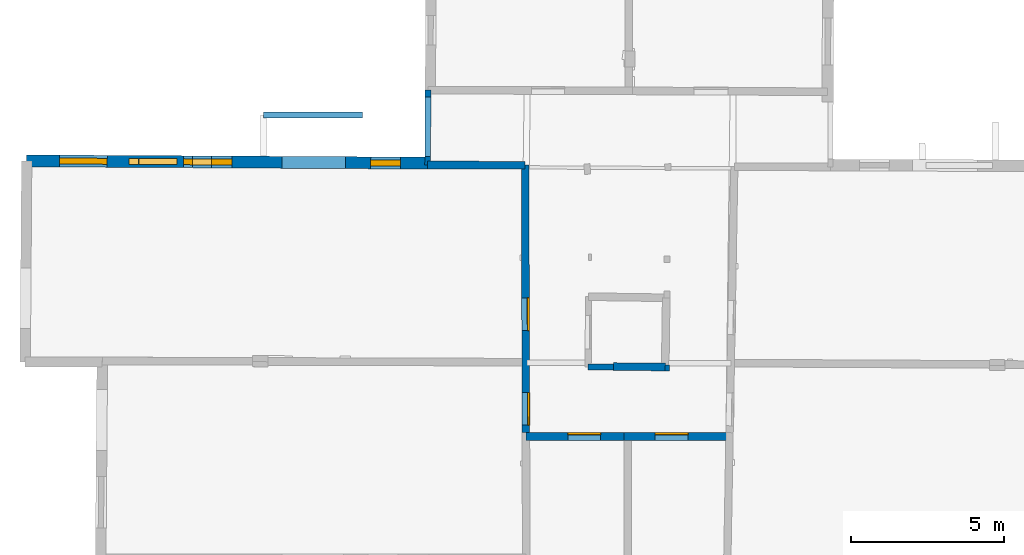
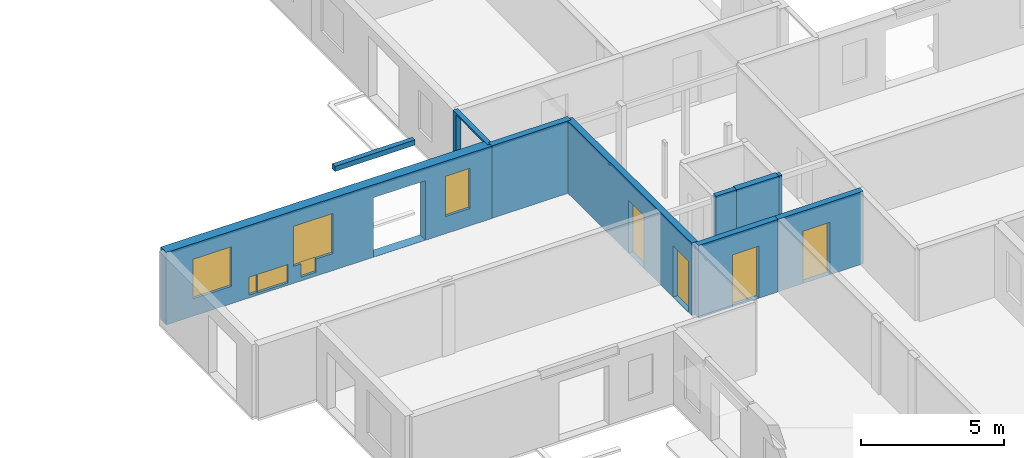
# One storey, part 5 of 17: 10 walls, 6 windows, 4 doors, 12 openings.
"""IFC2X3 building model written with IfcOpenShell, lengths in metres."""

from ifc_helpers import new_model, entity, si_unit, converted_unit, derived_unit, direction, frame, frame_2d, origin, origin_2d_with_axis, place, context, subcontext, project, spatial, polyline, rectangle, outline, extrude, clip, halfspace, source, transform, mapped, material, layer, layer_set, layer_usage, type_object, type_shapes, element, fill, save


model = new_model("IFC2X3")

# Units and contexts
model_context = context("Model", 3, precision=1e-05, world=origin(), true_north=direction((0.0, 1.0)))
body_context = subcontext(model_context, "Body", "Model", "MODEL_VIEW")
ifc_project = project(units=[si_unit("LENGTHUNIT", "METRE"), si_unit("AREAUNIT", "SQUARE_METRE"), si_unit("VOLUMEUNIT", "CUBIC_METRE"), converted_unit("PLANEANGLEUNIT", "DEGREE", entity("IfcRatioMeasure", 0.0174532925199433), si_unit("PLANEANGLEUNIT", "RADIAN"), dimensions=[0, 0, 0, 0, 0, 0, 0]), si_unit("MASSUNIT", "GRAM", prefix="KILO"), derived_unit("MASSDENSITYUNIT", [(si_unit("MASSUNIT", "GRAM", prefix="KILO"), 1), (si_unit("LENGTHUNIT", "METRE"), -3)]), derived_unit("MOMENTOFINERTIAUNIT", [(si_unit("LENGTHUNIT", "METRE"), 4)]), si_unit("TIMEUNIT", "SECOND"), si_unit("FREQUENCYUNIT", "HERTZ"), si_unit("THERMODYNAMICTEMPERATUREUNIT", "DEGREE_CELSIUS"), derived_unit("THERMALTRANSMITTANCEUNIT", [(si_unit("MASSUNIT", "GRAM", prefix="KILO"), 1), (si_unit("THERMODYNAMICTEMPERATUREUNIT", "KELVIN"), -1), (si_unit("TIMEUNIT", "SECOND"), -3)]), derived_unit("VOLUMETRICFLOWRATEUNIT", [(si_unit("LENGTHUNIT", "METRE"), 3), (si_unit("TIMEUNIT", "SECOND"), -1)]), si_unit("ELECTRICCURRENTUNIT", "AMPERE"), si_unit("ELECTRICVOLTAGEUNIT", "VOLT"), si_unit("POWERUNIT", "WATT"), si_unit("FORCEUNIT", "NEWTON", prefix="KILO"), si_unit("ILLUMINANCEUNIT", "LUX"), si_unit("LUMINOUSFLUXUNIT", "LUMEN"), si_unit("LUMINOUSINTENSITYUNIT", "CANDELA"), derived_unit("USERDEFINED", [(si_unit("MASSUNIT", "GRAM", prefix="KILO"), -1), (si_unit("LENGTHUNIT", "METRE"), -2), (si_unit("TIMEUNIT", "SECOND"), 3), (si_unit("LUMINOUSFLUXUNIT", "LUMEN"), 1)]), derived_unit("LINEARVELOCITYUNIT", [(si_unit("LENGTHUNIT", "METRE"), 1), (si_unit("TIMEUNIT", "SECOND"), -1)]), si_unit("PRESSUREUNIT", "PASCAL"), derived_unit("USERDEFINED", [(si_unit("LENGTHUNIT", "METRE"), -2), (si_unit("MASSUNIT", "GRAM", prefix="KILO"), 1), (si_unit("TIMEUNIT", "SECOND"), -2)]), derived_unit("LINEARFORCEUNIT", [(si_unit("MASSUNIT", "GRAM", prefix="KILO"), 1), (si_unit("LENGTHUNIT", "METRE"), 1), (si_unit("TIMEUNIT", "SECOND"), -2), (si_unit("LENGTHUNIT", "METRE"), -1)]), derived_unit("PLANARFORCEUNIT", [(si_unit("MASSUNIT", "GRAM", prefix="KILO"), 1), (si_unit("LENGTHUNIT", "METRE"), 1), (si_unit("TIMEUNIT", "SECOND"), -2), (si_unit("LENGTHUNIT", "METRE"), -2)])], contexts=[model_context])

# Site, building, storey
placement_1 = place(None, origin())
site = spatial("IfcSite", under=ifc_project, at=placement_1, CompositionType="ELEMENT")
building = spatial("IfcBuilding", under=site, at=placement_1, CompositionType="ELEMENT")
storey_placement = place(placement_1, frame((0.0, 0.0, 12.0782108306885)))
storey = spatial("IfcBuildingStorey", under=building, at=storey_placement, Name="Level 5", CompositionType="ELEMENT", Elevation=12.0782108306885)

# Wall, opening, door
ifc_material_1 = material(Name="Default wall")
ifc_layer_1 = layer(ifc_material_1, 0.25)
ifc_layer_set_1 = layer_set([ifc_layer_1], Name="wall_thickness_0.2500")
ifc_layer_usage_1 = layer_usage(ifc_layer_set_1, "AXIS2", "POSITIVE", -0.125)
wall_type_1 = type_object("IfcWallType", Name="wall_thickness_0.2500", PredefinedType="STANDARD", material=ifc_layer_set_1)
wall_1_placement = place(storey_placement, frame((2.85637753785305, 17.0102367488709, 0.0), z_axis=(0.0, 0.0, 1.0), x_axis=(0.999999929897867, -0.000374438594420214, 0.0)))
wall_1 = element("IfcWallStandardCase", 1, at=wall_1_placement, inside=storey, type_object=wall_type_1, material=ifc_layer_usage_1, Name="Wall:270", ObjectType="Wall", context=body_context, shape_type="Clipping", body=[
    clip(clip(extrude(outline(polyline([(3.20915006246216, -0.125), (3.20915006246216, 0.125), (0.0, 0.125), (0.0, -0.125), (3.20915006246216, -0.125)])), origin(), (0.0, 0.0, 1.0), 3.09134044647217), halfspace(frame((-14.890442149098, 2.57811716640344, 8.98689858314154), z_axis=(-0.0041479274100393, -0.389119399317111, 0.921177989192801), x_axis=(0.999955383416333, -0.00943198667611653, 0.000518463148508191)), False)), halfspace(frame((-4.14120761981484, 58.8320201531805, 5.79573318480268), z_axis=(-0.389898710511712, 0.00126843659211129, 0.920856876289642), x_axis=(0.920841319433383, -0.00520219987273768, 0.389902810378011)), False)),
])
opening_1_placement = place(wall_1_placement, frame((1.37507542569291, -0.125, 0.00578975677490234)))
opening_1 = element("IfcOpeningElement", 2, at=opening_1_placement, cuts=wall_1, Name="Opening : 1065 x 2215 : 235", ObjectType="Opening", context=body_context, shape_type="SweptSolid", body=[
    extrude(rectangle(XDim=1.065, YDim=2.215, at=frame_2d((1.1075, 0.5325), x_axis=(0.0, 1.0))), frame((0.0, 0.0, 0.0), z_axis=(0.0, 1.0, 0.0), x_axis=(0.0, 0.0, 1.0)), (0.0, 0.0, 1.0), 0.25),
])
ifc_material_2 = material(Name="Door Panel")
door_style_1 = type_object("IfcDoorStyle", Name="Door : 1065 x 2215mm", ConstructionType="NOTDEFINED", OperationType="SINGLE_SWING_RIGHT", ParameterTakesPrecedence=False, Sizeable=False, material=ifc_material_2)
shared_shape_1 = source(origin(), body_context, "Body", "SweptSolid", [
    extrude(rectangle(XDim=0.0625, YDim=1.065, at=origin_2d_with_axis()), frame((0.5325, 0.21875, 0.0), z_axis=(0.0, 0.0, 1.0), x_axis=(0.0, 1.0, 0.0)), (0.0, 0.0, 1.0), 2.215),
])
type_shapes(door_style_1, [shared_shape_1])
door_1_placement = place(opening_1_placement, origin())
door_1 = element("IfcDoor", 3, at=door_1_placement, inside=storey, type_object=door_style_1, Name="Door : 1065 x 2215mm : 41", ObjectType="Door : 1065 x 2215mm", OverallHeight=2.215, OverallWidth=1.065, context=body_context, shape_type="MappedRepresentation", body=[
    mapped(shared_shape_1, transform((0.0, 0.0, 0.0), scale=1.0)),
])
fill(opening_1, door_1)

wall_2_placement = place(storey_placement, frame((6.06552737534694, 17.0090351192323, 0.0), z_axis=(0.0, 0.0, 1.0), x_axis=(0.999999929913158, -0.000374397756172777, 0.0)))
wall_2 = element("IfcWallStandardCase", 4, at=wall_2_placement, inside=storey, type_object=wall_type_1, material=ifc_layer_usage_1, Name="Wall:271", ObjectType="Wall", context=body_context, shape_type="Clipping", body=[
    clip(clip(extrude(outline(polyline([(3.44384455975808, -0.125), (3.44384455975808, 0.125), (0.0, 0.125), (0.0, -0.125), (3.44384455975808, -0.125)])), origin(), (0.0, 0.0, 1.0), 3.09134044647217), halfspace(frame((-18.0995921062744, 2.57811790555912, 8.98689858314154), z_axis=(-0.00414794330099472, -0.389119399147716, 0.921177989192801), x_axis=(0.999955383031146, -0.00943202751254476, 0.000518463148508191)), False)), halfspace(frame((6.72844758520623, 60.2301062597763, 6.35864093399329), z_axis=(0.390496167337384, -0.00175759805737819, 0.920602875372374), x_axis=(-0.683452862184901, -0.670513843017829, 0.288623234499112)), False)),
])
opening_2_placement = place(wall_2_placement, frame((1.01592499556931, -0.125, 0.00578975677490234)))
opening_2 = element("IfcOpeningElement", 5, at=opening_2_placement, cuts=wall_2, Name="Opening : 1075 x 2230 : 236", ObjectType="Opening", context=body_context, shape_type="SweptSolid", body=[
    extrude(rectangle(XDim=1.075, YDim=2.23, at=frame_2d((1.115, 0.5375), x_axis=(0.0, 1.0))), frame((0.0, 0.0, 0.0), z_axis=(0.0, 1.0, 0.0), x_axis=(0.0, 0.0, 1.0)), (0.0, 0.0, 1.0), 0.25),
])
door_style_2 = type_object("IfcDoorStyle", Name="Door : 1075 x 2230mm", ConstructionType="NOTDEFINED", OperationType="SINGLE_SWING_RIGHT", ParameterTakesPrecedence=False, Sizeable=False, material=ifc_material_2)
shared_shape_2 = source(origin(), body_context, "Body", "SweptSolid", [
    extrude(rectangle(XDim=0.0625, YDim=1.075, at=origin_2d_with_axis()), frame((0.5375, 0.21875, 0.0), z_axis=(0.0, 0.0, 1.0), x_axis=(0.0, 1.0, 0.0)), (0.0, 0.0, 1.0), 2.23),
])
type_shapes(door_style_2, [shared_shape_2])
door_2_placement = place(opening_2_placement, origin())
door_2 = element("IfcDoor", 6, at=door_2_placement, inside=storey, type_object=door_style_2, Name="Door : 1075 x 2230mm : 42", ObjectType="Door : 1075 x 2230mm", OverallHeight=2.23, OverallWidth=1.075, context=body_context, shape_type="MappedRepresentation", body=[
    mapped(shared_shape_2, transform((0.0, 0.0, 0.0), scale=1.0)),
])
fill(opening_2, door_2)

# Wall, openings, doors
wall_3_placement = place(storey_placement, frame((2.83227659760263, 25.8755343846569, 0.0), z_axis=(0.0, 0.0, 1.0), x_axis=(0.00271868704684827, -0.999996304363542, 0.0)))
wall_3 = element("IfcWallStandardCase", 7, at=wall_3_placement, inside=storey, type_object=wall_type_1, material=ifc_layer_usage_1, Name="Wall:277", ObjectType="Wall", context=body_context, shape_type="Clipping", body=[
    clip(clip(extrude(outline(polyline([(8.74033152594136, -0.125), (8.74033152594136, 0.125), (0.0, 0.125), (0.0, -0.125), (8.74033152594136, -0.125)])), origin(), (0.0, 0.0, 1.0), 3.09134044647217), halfspace(frame((6.69725716482242, 21.529363592377, 9.08176747891542), z_axis=(-0.389111321245445, 0.00439635317830493, 0.921180249330909), x_axis=(-0.0125248653897104, -0.999921426386347, -0.000518459702406835)), False)), halfspace(frame((-49.9792175904594, -3.95921419066539, 5.79573318480268), z_axis=(-0.00247443560940084, -0.389892921913823, 0.920856876289642), x_axis=(0.00805045143379944, 0.920820823337006, 0.389902810378011)), False)),
])
opening_3_placement = place(wall_3_placement, frame((4.33737831793676, -0.125, 0.00578975677490234)))
opening_3 = element("IfcOpeningElement", 8, at=opening_3_placement, cuts=wall_3, Name="Opening : 1070 x 2245 : 240", ObjectType="Opening", context=body_context, shape_type="SweptSolid", body=[
    extrude(rectangle(XDim=1.07, YDim=2.245, at=frame_2d((1.1225, 0.535), x_axis=(0.0, 1.0))), frame((0.0, 0.0, 0.0), z_axis=(0.0, 1.0, 0.0), x_axis=(0.0, 0.0, 1.0)), (0.0, 0.0, 1.0), 0.25),
])
opening_4_placement = place(wall_3_placement, frame((7.43635636937285, -0.125, 0.00578975677490234)))
opening_4 = element("IfcOpeningElement", 9, at=opening_4_placement, cuts=wall_3, Name="Opening : 1060 x 2185 : 241", ObjectType="Opening", context=body_context, shape_type="SweptSolid", body=[
    extrude(rectangle(XDim=1.06, YDim=2.185, at=frame_2d((1.0925, 0.53), x_axis=(0.0, 1.0))), frame((0.0, 0.0, 0.0), z_axis=(0.0, 1.0, 0.0), x_axis=(0.0, 0.0, 1.0)), (0.0, 0.0, 1.0), 0.25),
])
door_style_3 = type_object("IfcDoorStyle", Name="Door : 1070 x 2245mm", ConstructionType="NOTDEFINED", OperationType="SINGLE_SWING_RIGHT", ParameterTakesPrecedence=False, Sizeable=False, material=ifc_material_2)
shared_shape_3 = source(origin(), body_context, "Body", "SweptSolid", [
    extrude(rectangle(XDim=0.0625, YDim=1.07, at=origin_2d_with_axis()), frame((0.535, 0.21875, 0.0), z_axis=(0.0, 0.0, 1.0), x_axis=(0.0, 1.0, 0.0)), (0.0, 0.0, 1.0), 2.245),
])
type_shapes(door_style_3, [shared_shape_3])
door_3_placement = place(opening_3_placement, origin())
door_3 = element("IfcDoor", 10, at=door_3_placement, inside=storey, type_object=door_style_3, Name="Door : 1070 x 2245mm : 44", ObjectType="Door : 1070 x 2245mm", OverallHeight=2.245, OverallWidth=1.07, context=body_context, shape_type="MappedRepresentation", body=[
    mapped(shared_shape_3, transform((0.0, 0.0, 0.0), scale=1.0)),
])
fill(opening_3, door_3)
door_style_4 = type_object("IfcDoorStyle", Name="Door : 1060 x 2185mm", ConstructionType="NOTDEFINED", OperationType="SINGLE_SWING_RIGHT", ParameterTakesPrecedence=False, Sizeable=False, material=ifc_material_2)
shared_shape_4 = source(origin(), body_context, "Body", "SweptSolid", [
    extrude(rectangle(XDim=0.0625, YDim=1.06, at=origin_2d_with_axis()), frame((0.53, 0.21875, 0.0), z_axis=(0.0, 0.0, 1.0), x_axis=(0.0, 1.0, 0.0)), (0.0, 0.0, 1.0), 2.185),
])
type_shapes(door_style_4, [shared_shape_4])
door_4_placement = place(opening_4_placement, origin())
door_4 = element("IfcDoor", 11, at=door_4_placement, inside=storey, type_object=door_style_4, Name="Door : 1060 x 2185mm : 45", ObjectType="Door : 1060 x 2185mm", OverallHeight=2.185, OverallWidth=1.06, context=body_context, shape_type="MappedRepresentation", body=[
    mapped(shared_shape_4, transform((0.0, 0.0, 0.0), scale=1.0)),
])
fill(opening_4, door_4)

# Walls
wall_4_placement = place(storey_placement, frame((7.40944958897362, 19.2779263407526, 0.0), z_axis=(0.0, 0.0, 1.0), x_axis=(-0.999947428108919, 0.0102538294484715, 0.0)))
element("IfcWallStandardCase", 12, at=wall_4_placement, inside=storey, type_object=wall_type_1, material=ifc_layer_usage_1, Name="Wall:302", ObjectType="Wall", context=body_context, shape_type="Clipping", body=[
    clip(clip(extrude(outline(polyline([(1.68881473251791, -0.125), (1.68881473251791, 0.125), (0.0, 0.125), (0.0, -0.125), (1.68881473251791, -0.125)])), origin(), (0.0, 0.0, 1.0), 3.09134044647217), halfspace(frame((19.4447659186477, -0.116625767860828, 8.98689858314154), z_axis=(0.000303454965726463, 0.38914138836905, 0.921177989192801), x_axis=(-0.999999765495486, -0.000447442663645624, 0.000518463148508191)), False)), halfspace(frame((-4.81249211672698, -58.0110879272227, 6.35864093399329), z_axis=(-0.390494474070463, -0.00210037533535356, 0.920602875372374), x_axis=(0.67679519923326, 0.677233258783178, 0.288623234499112)), False)),
])
wall_5_placement = place(storey_placement, frame((-0.353940042868601, 25.8813726616084, 0.0), z_axis=(0.0, 0.0, 1.0), x_axis=(0.999998320079132, -0.00183298633782044, 0.0)))
element("IfcWallStandardCase", 13, at=wall_5_placement, inside=storey, type_object=wall_type_1, material=ifc_layer_usage_1, Name="Wall:312", ObjectType="Wall", context=body_context, shape_type="Clipping", body=[
    clip(clip(extrude(outline(polyline([(3.18622206459892, -0.125), (3.18622206459892, 0.125), (0.0, 0.125), (0.0, -0.125), (3.18622206459892, -0.125)])), origin(), (0.0, 0.0, 1.0), 3.09134044647217), halfspace(frame((24.7458462131494, -6.59919137731351, 9.08176747891542), z_axis=(0.00262520440548051, 0.389127301206782, 0.921180249330909), x_axis=(-0.999968077287342, 0.00797343124338788, -0.000518459702406836)), False)), halfspace(frame((-1.00043969599681, 49.9606808818491, 5.79573318480268), z_axis=(-0.389900145859414, 0.000699749163370155, 0.920856876289642), x_axis=(0.920847927610484, -0.00385910284984901, 0.389902810378011)), False)),
])
ifc_layer_2 = layer(ifc_material_1, 0.2)
ifc_layer_set_2 = layer_set([ifc_layer_2], Name="wall_thickness_0.2000")
ifc_layer_usage_2 = layer_usage(ifc_layer_set_2, "AXIS2", "POSITIVE", -0.1)
wall_type_2 = type_object("IfcWallType", Name="wall_thickness_0.2000", PredefinedType="STANDARD", material=ifc_layer_set_2)
wall_6_placement = place(storey_placement, frame((4.89160223970066, 19.2841847970237, 0.0), z_axis=(0.0, 0.0, 1.0), x_axis=(0.999921368176657, -0.0125402337985105, 0.0)))
element("IfcWallStandardCase", 14, at=wall_6_placement, inside=storey, type_object=wall_type_2, material=ifc_layer_usage_2, Name="Wall:231", ObjectType="Wall", context=body_context, shape_type="Clipping", body=[
    clip(clip(extrude(outline(polyline([(0.828631708030578, -0.1), (0.828631708030578, 0.1), (0.0, 0.1), (0.0, -0.1), (0.828631708030578, -0.1)])), origin(), (0.0, 0.0, 1.0), 3.09134044647217), halfspace(frame((-16.9272539088385, 0.0974804372287028, 8.98689858314154), z_axis=(0.000586337599738846, -0.389141064955791, 0.921177989192801), x_axis=(0.99999612823348, 0.00273399232129082, 0.000518463148508191)), False)), halfspace(frame((-6.86318996139648, 56.4779935696316, 5.79573318480268), z_axis=(-0.389885287098565, -0.00347509627965071, 0.920856876289642), x_axis=(0.92083646035459, 0.00600097833352424, 0.389902810378011)), False)),
])
wall_7_placement = place(storey_placement, frame((7.40909119615208, 19.2526143624534, 0.0), z_axis=(0.0, 0.0, 1.0), x_axis=(0.999921287633949, -0.0125466543933555, 0.0)))
element("IfcWallStandardCase", 15, at=wall_7_placement, inside=storey, type_object=wall_type_2, material=ifc_layer_usage_2, Name="Wall:232", ObjectType="Wall", context=body_context, shape_type="Clipping", body=[
    clip(clip(extrude(outline(polyline([(0.135754303553909, -0.1), (0.135754303553909, 0.1), (0.0, 0.1), (0.0, -0.1), (0.135754303553909, -0.1)])), origin(), (0.0, 0.0, 1.0), 3.09134044647217), halfspace(frame((-19.4449414366919, 0.0973536313475373, 8.98689858314154), z_axis=(0.000588836313421407, -0.389141061182837, 0.921177989192801), x_axis=(0.999996110657627, 0.00274041339637978, 0.000518463148508191)), False)), halfspace(frame((4.67950242308288, 58.047284818305, 6.35864093399329), z_axis=(0.390488631410523, 0.00299576288338801, 0.920602875372374), x_axis=(-0.675240542827812, -0.678783351172429, 0.288623234499112)), False)),
])
placement_2 = place(placement_1, frame((0.0, 0.0, 14.9530000686646)))
wall_8_placement = place(placement_2, frame((-5.72310910003213, 27.5122237958999, 0.0), z_axis=(0.0, 0.0, 1.0), x_axis=(0.999999799953544, 0.000632528949814511, 0.0)))
element("IfcWallStandardCase", 16, at=wall_8_placement, inside=storey, type_object=wall_type_2, material=ifc_layer_usage_2, Name="Wall:286", ObjectType="Wall", context=body_context, shape_type="SweptSolid", body=[
    extrude(outline(polyline([(3.23254411513434, -0.1), (3.23254411513434, 0.1), (0.0, 0.1), (0.0, -0.1), (3.23254411513434, -0.1)])), origin(), (0.0, 0.0, 1.0), 0.216551208496094),
])

# Wall, openings, windows
ifc_layer_3 = layer(ifc_material_1, 0.389999985694885)
ifc_layer_set_3 = layer_set([ifc_layer_3], Name="wall_thickness_0.3900")
ifc_layer_usage_3 = layer_usage(ifc_layer_set_3, "AXIS2", "POSITIVE", -0.194999992847443)
wall_type_3 = type_object("IfcWallType", Name="wall_thickness_0.3900", PredefinedType="STANDARD", material=ifc_layer_set_3)
wall_9_placement = place(storey_placement, frame((-13.4560524146002, 26.0169420445448, 0.0), z_axis=(0.0, 0.0, 1.0), x_axis=(0.999983693809683, -0.00571070177315652, 0.0)))
wall_9 = element("IfcWallStandardCase", 17, at=wall_9_placement, inside=storey, type_object=wall_type_3, material=ifc_layer_usage_3, Name="Wall:329", ObjectType="Wall", context=body_context, shape_type="Clipping", body=[
    clip(extrude(outline(polyline([(13.1026430441447, -0.194999992847443), (13.1026430441447, 0.194999992847443), (0.0, 0.194999992847443), (0.0, -0.194999992847443), (13.1026430441447, -0.194999992847443)])), origin(), (0.0, 0.0, 1.0), 3.09134044647217), halfspace(frame((37.8739230055619, -6.56392882556554, 9.08176747891542), z_axis=(0.00111625182829218, 0.389134555423314, 0.921180249330909), x_axis=(-0.999991477941119, 0.00409575935259031, -0.000518459702406835)), False)),
])
opening_5_placement = place(wall_9_placement, frame((8.34162098007375, -0.194999992847443, 0.00578975677490234)))
element("IfcOpeningElement", 18, at=opening_5_placement, cuts=wall_9, Name="Opening : 2080 x 2535 : 272", ObjectType="Opening", context=body_context, shape_type="SweptSolid", body=[
    extrude(rectangle(XDim=2.08, YDim=2.535, at=frame_2d((1.2675, 1.04), x_axis=(0.0, 1.0))), frame((0.0, 0.0, 0.0), z_axis=(0.0, 1.0, 0.0), x_axis=(0.0, 0.0, 1.0)), (0.0, 0.0, 1.0), 0.389999985694885),
])
opening_6_placement = place(wall_9_placement, frame((1.07239940121938, -0.194999992847443, 0.740789413452148)))
opening_6 = element("IfcOpeningElement", 19, at=opening_6_placement, cuts=wall_9, Name="Opening : 1560 x 1690 : 273", ObjectType="Opening", context=body_context, shape_type="SweptSolid", body=[
    extrude(rectangle(XDim=1.56, YDim=1.69, at=frame_2d((0.845, 0.78), x_axis=(0.0, 1.0))), frame((0.0, 0.0, 0.0), z_axis=(0.0, 1.0, 0.0), x_axis=(0.0, 0.0, 1.0)), (0.0, 0.0, 1.0), 0.389999985694885),
])
opening_7_placement = place(wall_9_placement, frame((5.12239887578709, -0.194999992847443, 0.725790023803711)))
opening_7 = element("IfcOpeningElement", 20, at=opening_7_placement, cuts=wall_9, Name="Opening : 1590 x 1710 : 274", ObjectType="Opening", context=body_context, shape_type="SweptSolid", body=[
    extrude(rectangle(XDim=1.59, YDim=1.71, at=frame_2d((0.855, 0.795), x_axis=(0.0, 1.0))), frame((0.0, 0.0, 0.0), z_axis=(0.0, 1.0, 0.0), x_axis=(0.0, 0.0, 1.0)), (0.0, 0.0, 1.0), 0.389999985694885),
])
opening_8_placement = place(wall_9_placement, frame((3.33662413264357, -0.194999992847443, 0.115789413452148)))
opening_8 = element("IfcOpeningElement", 21, at=opening_8_placement, cuts=wall_9, Name="Opening : 325 x 770 : 275", ObjectType="Opening", context=body_context, shape_type="SweptSolid", body=[
    extrude(rectangle(XDim=0.325, YDim=0.77, at=frame_2d((0.385, 0.1625), x_axis=(0.0, 1.0))), frame((0.0, 0.0, 0.0), z_axis=(0.0, 1.0, 0.0), x_axis=(0.0, 0.0, 1.0)), (0.0, 0.0, 1.0), 0.389999985694885),
])
opening_9_placement = place(wall_9_placement, frame((3.67162486489846, -0.194999992847443, 0.100790023803711)))
opening_9 = element("IfcOpeningElement", 22, at=opening_9_placement, cuts=wall_9, Name="Opening : 1235 x 785 : 276", ObjectType="Opening", context=body_context, shape_type="SweptSolid", body=[
    extrude(rectangle(XDim=1.235, YDim=0.785, at=frame_2d((0.3925, 0.6175), x_axis=(0.0, 1.0))), frame((0.0, 0.0, 0.0), z_axis=(0.0, 1.0, 0.0), x_axis=(0.0, 0.0, 1.0)), (0.0, 0.0, 1.0), 0.389999985694885),
])
opening_10_placement = place(wall_9_placement, frame((5.42162384129158, -0.194999992847443, 0.160789489746094)))
opening_10 = element("IfcOpeningElement", 23, at=opening_10_placement, cuts=wall_9, Name="Opening : 615 x 585 : 277", ObjectType="Opening", context=body_context, shape_type="SweptSolid", body=[
    extrude(rectangle(XDim=0.615, YDim=0.585, at=frame_2d((0.2925, 0.3075), x_axis=(0.0, 1.0))), frame((0.0, 0.0, 0.0), z_axis=(0.0, 1.0, 0.0), x_axis=(0.0, 0.0, 1.0)), (0.0, 0.0, 1.0), 0.389999985694885),
])
opening_11_placement = place(wall_9_placement, frame((11.2423993665503, -0.194999992847443, 0.73578929901123)))
opening_11 = element("IfcOpeningElement", 24, at=opening_11_placement, cuts=wall_9, Name="Opening : 975 x 1715 : 278", ObjectType="Opening", context=body_context, shape_type="SweptSolid", body=[
    extrude(rectangle(XDim=0.975, YDim=1.715, at=frame_2d((0.8575, 0.4875), x_axis=(0.0, 1.0))), frame((0.0, 0.0, 0.0), z_axis=(0.0, 1.0, 0.0), x_axis=(0.0, 0.0, 1.0)), (0.0, 0.0, 1.0), 0.389999985694885),
])
ifc_material_3 = material(Name="Window Default")
window_style_1 = type_object("IfcWindowStyle", Name="Window : 1560 x 1690mm", ConstructionType="NOTDEFINED", OperationType="NOTDEFINED", ParameterTakesPrecedence=False, Sizeable=False, material=ifc_material_3)
shared_shape_5 = source(origin(), body_context, "Body", "SweptSolid", [
    extrude(rectangle(XDim=0.194999992847443, YDim=1.56, at=origin_2d_with_axis()), frame((0.78, 0.194999992847443, 0.0), z_axis=(0.0, 0.0, 1.0), x_axis=(0.0, 1.0, 0.0)), (0.0, 0.0, 1.0), 1.69),
])
type_shapes(window_style_1, [shared_shape_5])
window_1_placement = place(opening_6_placement, origin())
window_1 = element("IfcWindow", 25, at=window_1_placement, inside=storey, type_object=window_style_1, Name="Window : 1560 x 1690mm : 147", ObjectType="Window : 1560 x 1690mm", OverallHeight=1.69, OverallWidth=1.56, context=body_context, shape_type="MappedRepresentation", body=[
    mapped(shared_shape_5, transform((0.0, 0.0, 0.0), scale=1.0)),
])
fill(opening_6, window_1)
window_style_2 = type_object("IfcWindowStyle", Name="Window : 1590 x 1710mm", ConstructionType="NOTDEFINED", OperationType="NOTDEFINED", ParameterTakesPrecedence=False, Sizeable=False, material=ifc_material_3)
shared_shape_6 = source(origin(), body_context, "Body", "SweptSolid", [
    extrude(rectangle(XDim=0.194999992847443, YDim=1.59, at=origin_2d_with_axis()), frame((0.795, 0.194999992847443, 0.0), z_axis=(0.0, 0.0, 1.0), x_axis=(0.0, 1.0, 0.0)), (0.0, 0.0, 1.0), 1.71),
])
type_shapes(window_style_2, [shared_shape_6])
window_2_placement = place(opening_7_placement, origin())
window_2 = element("IfcWindow", 26, at=window_2_placement, inside=storey, type_object=window_style_2, Name="Window : 1590 x 1710mm : 148", ObjectType="Window : 1590 x 1710mm", OverallHeight=1.71, OverallWidth=1.59, context=body_context, shape_type="MappedRepresentation", body=[
    mapped(shared_shape_6, transform((0.0, 0.0, 0.0), scale=1.0)),
])
fill(opening_7, window_2)
window_style_3 = type_object("IfcWindowStyle", Name="Window : 325 x 770mm", ConstructionType="NOTDEFINED", OperationType="NOTDEFINED", ParameterTakesPrecedence=False, Sizeable=False, material=ifc_material_3)
shared_shape_7 = source(origin(), body_context, "Body", "SweptSolid", [
    extrude(rectangle(XDim=0.194999992847443, YDim=0.325, at=origin_2d_with_axis()), frame((0.1625, 0.194999992847443, 0.0), z_axis=(0.0, 0.0, 1.0), x_axis=(0.0, 1.0, 0.0)), (0.0, 0.0, 1.0), 0.77),
])
type_shapes(window_style_3, [shared_shape_7])
window_3_placement = place(opening_8_placement, origin())
window_3 = element("IfcWindow", 27, at=window_3_placement, inside=storey, type_object=window_style_3, Name="Window : 325 x 770mm : 149", ObjectType="Window : 325 x 770mm", OverallHeight=0.77, OverallWidth=0.325, context=body_context, shape_type="MappedRepresentation", body=[
    mapped(shared_shape_7, transform((0.0, 0.0, 0.0), scale=1.0)),
])
fill(opening_8, window_3)
window_style_4 = type_object("IfcWindowStyle", Name="Window : 1235 x 785mm", ConstructionType="NOTDEFINED", OperationType="NOTDEFINED", ParameterTakesPrecedence=False, Sizeable=False, material=ifc_material_3)
shared_shape_8 = source(origin(), body_context, "Body", "SweptSolid", [
    extrude(rectangle(XDim=0.194999992847443, YDim=1.235, at=origin_2d_with_axis()), frame((0.6175, 0.194999992847443, 0.0), z_axis=(0.0, 0.0, 1.0), x_axis=(0.0, 1.0, 0.0)), (0.0, 0.0, 1.0), 0.785),
])
type_shapes(window_style_4, [shared_shape_8])
window_4_placement = place(opening_9_placement, origin())
window_4 = element("IfcWindow", 28, at=window_4_placement, inside=storey, type_object=window_style_4, Name="Window : 1235 x 785mm : 150", ObjectType="Window : 1235 x 785mm", OverallHeight=0.785, OverallWidth=1.235, context=body_context, shape_type="MappedRepresentation", body=[
    mapped(shared_shape_8, transform((0.0, 0.0, 0.0), scale=1.0)),
])
fill(opening_9, window_4)
window_style_5 = type_object("IfcWindowStyle", Name="Window : 615 x 585mm", ConstructionType="NOTDEFINED", OperationType="NOTDEFINED", ParameterTakesPrecedence=False, Sizeable=False, material=ifc_material_3)
shared_shape_9 = source(origin(), body_context, "Body", "SweptSolid", [
    extrude(rectangle(XDim=0.194999992847443, YDim=0.615, at=origin_2d_with_axis()), frame((0.3075, 0.194999992847443, 0.0), z_axis=(0.0, 0.0, 1.0), x_axis=(0.0, 1.0, 0.0)), (0.0, 0.0, 1.0), 0.585),
])
type_shapes(window_style_5, [shared_shape_9])
window_5_placement = place(opening_10_placement, origin())
window_5 = element("IfcWindow", 29, at=window_5_placement, inside=storey, type_object=window_style_5, Name="Window : 615 x 585mm : 151", ObjectType="Window : 615 x 585mm", OverallHeight=0.585, OverallWidth=0.615, context=body_context, shape_type="MappedRepresentation", body=[
    mapped(shared_shape_9, transform((0.0, 0.0, 0.0), scale=1.0)),
])
fill(opening_10, window_5)
window_style_6 = type_object("IfcWindowStyle", Name="Window : 975 x 1715mm", ConstructionType="NOTDEFINED", OperationType="NOTDEFINED", ParameterTakesPrecedence=False, Sizeable=False, material=ifc_material_3)
shared_shape_10 = source(origin(), body_context, "Body", "SweptSolid", [
    extrude(rectangle(XDim=0.194999992847443, YDim=0.975, at=origin_2d_with_axis()), frame((0.4875, 0.194999992847443, 0.0), z_axis=(0.0, 0.0, 1.0), x_axis=(0.0, 1.0, 0.0)), (0.0, 0.0, 1.0), 1.715),
])
type_shapes(window_style_6, [shared_shape_10])
window_6_placement = place(opening_11_placement, origin())
window_6 = element("IfcWindow", 30, at=window_6_placement, inside=storey, type_object=window_style_6, Name="Window : 975 x 1715mm : 152", ObjectType="Window : 975 x 1715mm", OverallHeight=1.715, OverallWidth=0.975, context=body_context, shape_type="MappedRepresentation", body=[
    mapped(shared_shape_10, transform((0.0, 0.0, 0.0), scale=1.0)),
])
fill(opening_11, window_6)

# Wall, opening
ifc_layer_4 = layer(ifc_material_1, 0.189999997615814)
ifc_layer_set_4 = layer_set([ifc_layer_4], Name="wall_thickness_0.1900")
ifc_layer_usage_4 = layer_usage(ifc_layer_set_4, "AXIS2", "POSITIVE", -0.0949999988079071)
wall_type_4 = type_object("IfcWallType", Name="wall_thickness_0.1900", PredefinedType="STANDARD", material=ifc_layer_set_4)
wall_10_placement = place(storey_placement, frame((-0.341202025636473, 28.3289504849418, 0.0), z_axis=(0.0, 0.0, 1.0), x_axis=(-0.00520422440392385, -0.999986457932483, 0.0)))
wall_10 = element("IfcWallStandardCase", 31, at=wall_10_placement, inside=storey, type_object=wall_type_4, material=ifc_layer_usage_4, Name="Wall:339", ObjectType="Wall", context=body_context, shape_type="Clipping", body=[
    clip(extrude(outline(polyline([(2.44761348327146, -0.0949999988079071), (2.44761348327146, 0.0949999988079071), (0.0, 0.0949999988079071), (0.0, -0.0949999988079071), (2.44761348327146, -0.0949999988079071)])), origin(), (0.0, 0.0, 1.0), 3.09134044647217), halfspace(frame((-47.5094132645753, -1.16886426385117, 5.79573318480268), z_axis=(0.000614707296283124, -0.389900289208694, 0.920856876289642), x_axis=(0.000754668526106848, 0.920855704730521, 0.389902810378011)), False)),
])
opening_12_placement = place(wall_10_placement, frame((0.225617604147143, -0.0949999988079071, 0.00578975677490234)))
element("IfcOpeningElement", 32, at=opening_12_placement, cuts=wall_10, Name="Opening : 1945 x 3005 : 289", ObjectType="Opening", context=body_context, shape_type="SweptSolid", body=[
    extrude(rectangle(XDim=1.945, YDim=3.005, at=frame_2d((1.5025, 0.9725), x_axis=(0.0, 1.0))), frame((0.0, 0.0, 0.0), z_axis=(0.0, 1.0, 0.0), x_axis=(0.0, 0.0, 1.0)), (0.0, 0.0, 1.0), 0.189999997615814),
])

save(model, "model.ifc")
